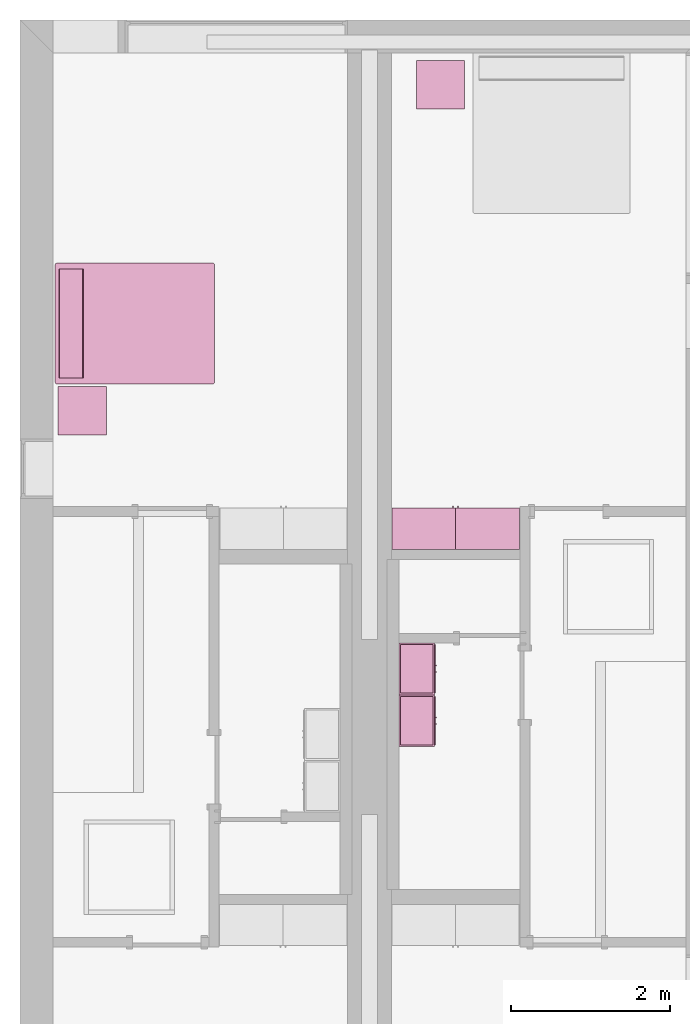
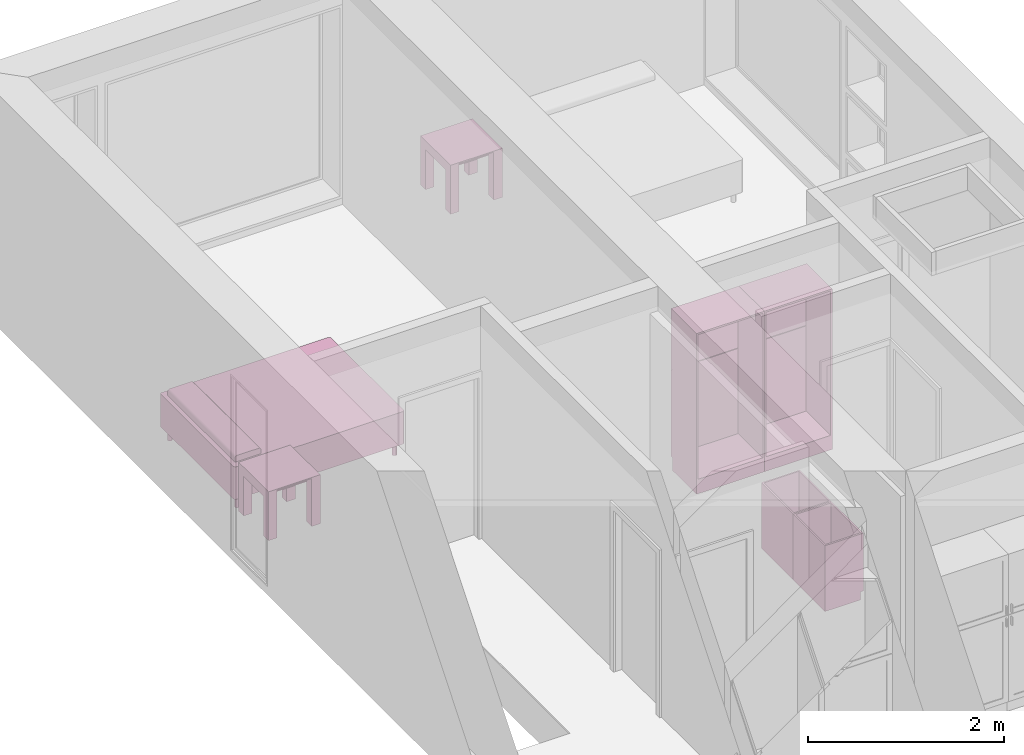
# One storey, part 9 of 10: 7 furnishings, 2 openings.
"""IFC2X3 building model written with IfcOpenShell, lengths in metres."""

from ifc_helpers import new_model, entity, si_unit, converted_unit, derived_unit, direction, frame, frame_2d, origin, origin_2d_with_axis, place, context, subcontext, project, spatial, polyline, circle_curve, parameter, trimmed, segment, composite_curve, rectangle, circle, outline, extrude, faceted_brep, source, transform, mapped, material, material_list, type_object, type_shapes, element, save


model = new_model("IFC2X3")

# Units and contexts
model_context = context("Model", 3, precision=1e-05, world=origin(), true_north=direction((6.12303176911189e-17, 1.0)))
body_context = subcontext(model_context, "Body", "Model", "MODEL_VIEW")
ifc_project = project(units=[derived_unit("USERDEFINED", [(si_unit("LENGTHUNIT", "METRE"), -2), (si_unit("TIMEUNIT", "SECOND"), -2), (si_unit("MASSUNIT", "GRAM", prefix="KILO"), 1)]), si_unit("FREQUENCYUNIT", "HERTZ"), si_unit("LENGTHUNIT", "METRE"), si_unit("ILLUMINANCEUNIT", "LUX"), derived_unit("LINEARVELOCITYUNIT", [(si_unit("TIMEUNIT", "SECOND"), -1), (si_unit("LENGTHUNIT", "METRE"), 1)]), si_unit("POWERUNIT", "WATT"), si_unit("LUMINOUSINTENSITYUNIT", "CANDELA"), si_unit("AREAUNIT", "SQUARE_METRE"), si_unit("VOLUMEUNIT", "CUBIC_METRE"), si_unit("ELECTRICVOLTAGEUNIT", "VOLT"), si_unit("PRESSUREUNIT", "PASCAL"), converted_unit("PLANEANGLEUNIT", "DEGREE", entity("IfcRatioMeasure", 0.0174532925199433), si_unit("PLANEANGLEUNIT", "RADIAN"), dimensions=[0, 0, 0, 0, 0, 0, 0]), si_unit("THERMODYNAMICTEMPERATUREUNIT", "DEGREE_CELSIUS"), si_unit("MASSUNIT", "GRAM", prefix="KILO"), derived_unit("VOLUMETRICFLOWRATEUNIT", [(si_unit("LENGTHUNIT", "METRE"), 3), (si_unit("TIMEUNIT", "SECOND"), -1)]), si_unit("TIMEUNIT", "SECOND"), si_unit("LUMINOUSFLUXUNIT", "LUMEN"), derived_unit("USERDEFINED", [(si_unit("LUMINOUSFLUXUNIT", "LUMEN"), 1), (si_unit("TIMEUNIT", "SECOND"), 3), (si_unit("MASSUNIT", "GRAM", prefix="KILO"), -1), (si_unit("LENGTHUNIT", "METRE"), -2)]), si_unit("FORCEUNIT", "NEWTON", prefix="KILO"), si_unit("ELECTRICCURRENTUNIT", "AMPERE"), derived_unit("THERMALTRANSMITTANCEUNIT", [(si_unit("TIMEUNIT", "SECOND"), -3), (si_unit("THERMODYNAMICTEMPERATUREUNIT", "KELVIN"), -1), (si_unit("MASSUNIT", "GRAM", prefix="KILO"), 1)])], contexts=[model_context])

# Site, building, storey, space
site_placement = place(None, origin())
site = spatial("IfcSite", under=ifc_project, at=site_placement, CompositionType="ELEMENT")
building_placement = place(site_placement, origin())
building = spatial("IfcBuilding", under=site, at=building_placement, CompositionType="ELEMENT")
storey_placement = place(building_placement, frame((0.0, 0.0, 3.10000000000038)))
storey = spatial("IfcBuildingStorey", under=building, at=storey_placement, Name="Level 2", CompositionType="ELEMENT", Elevation=3.10000000000038)
space_1_placement = place(storey_placement, origin())
space_1 = spatial("IfcSpace", under=storey, at=space_1_placement, CompositionType="ELEMENT", InteriorOrExteriorSpace="INTERNAL")

# Furnishing, opening
ifc_material_1 = material(Name="Cabinets")
ifc_material_2 = material(Name="Cabinets - Handles")
ifc_material_3 = material(Name="Cabinets - Panel")
ifc_material_list_1 = material_list([ifc_material_1, ifc_material_2, ifc_material_3])
ifc_material_list_2 = material_list([ifc_material_1, ifc_material_2, ifc_material_3])
furniture_type_1 = type_object("IfcFurnitureType", Name="800 mm", AssemblyPlace="NOTDEFINED", material=ifc_material_list_2)
shared_shape_1 = source(origin(), body_context, "Body", "SweptSolid", [
    extrude(outline(polyline([(-0.376138481652111, -0.4), (0.376138481652111, -0.4), (0.376138481652111, 0.4), (-0.376138481652111, 0.4), (-0.376138481652111, -0.4)]), holes=[polyline([(-0.312638481652032, -0.336499999999999), (-0.312638481652032, 0.336499999999999), (0.315813481652108, 0.336499999999999), (0.315813481652108, -0.336499999999999), (-0.312638481652032, -0.336499999999999)])]), frame((0.0187377049180258, -0.52, 1.62386151834792), z_axis=(0.0, 1.0, 0.0), x_axis=(0.0, 0.0, -1.0)), (0.0, 0.0, 1.0), 0.01905),
    extrude(outline(polyline([(-0.172299999999634, 0.558941666666897), (-0.172300000000835, -1.2794708333333), (0.328649999999164, -1.27947083333363), (0.32865000000047, 0.720529166666412), (-0.156349999999529, 0.720529166666729), (-0.156349999999635, 0.558941666666897), (-0.172299999999634, 0.558941666666897)])), frame((-0.381262295081959, -0.328649999999999, 0.720529166666627), z_axis=(-1.0, 0.0, 0.0), x_axis=(0.0, 1.0, 0.0)), (0.0, 0.0, -1.0), 0.8),
    extrude(rectangle(XDim=0.01905, YDim=0.761899999999999, at=origin_2d_with_axis()), frame((0.018737704918025, -0.009525, 0.180637499999846), z_axis=(0.0, 0.0, 1.0), x_axis=(0.0, 1.0, 0.0)), (0.0, 0.0, 1.0), 1.80031250000011),
    extrude(rectangle(XDim=0.00634999999999998, YDim=0.672999999999998, at=origin_2d_with_axis()), frame((0.0187377049180256, -0.504125, 0.225087499999839), z_axis=(0.0, 0.0, 1.0), x_axis=(0.0, 1.0, 0.0)), (0.0, 0.0, 1.0), 0.955960536695974),
    extrude(outline(polyline([(-0.4, -0.539892768347997), (0.4, -0.539892768347997), (0.4, 0.539892768347997), (-0.4, 0.539892768347997), (-0.4, -0.539892768347997)]), holes=[polyline([(-0.336499999999999, 0.479567768347999), (0.336499999999999, 0.479567768347999), (0.336499999999999, -0.476392768347979), (-0.336499999999999, -0.476392768347979), (-0.336499999999999, 0.479567768347999)])]), frame((0.0187377049180257, -0.52, 0.701480268347818), z_axis=(0.0, 1.0, 0.0), x_axis=(-1.0, 0.0, 0.0)), (0.0, 0.0, 1.0), 0.01905),
    extrude(rectangle(XDim=0.0254, YDim=0.0125322316306444, at=frame_2d((0.0, 3.38271077815477e-17), x_axis=(1.0, 0.0))), frame((0.387071589102703, -0.532700000000001, 1.26994803669581), z_axis=(0.0, 0.0, 1.0), x_axis=(0.0, 1.0, 0.0)), (0.0, 0.0, 1.0), 0.1016),
    extrude(rectangle(XDim=0.00634999999999998, YDim=0.672999999999998, at=origin_2d_with_axis()), frame((0.0187377049180261, -0.504125, 1.30804803669582), z_axis=(0.0, 0.0, 1.0), x_axis=(0.0, 1.0, 0.0)), (0.0, 0.0, 1.0), 0.62845196330414),
    extrude(rectangle(XDim=0.0254, YDim=0.0125322316306447, at=frame_2d((0.0, -3.38271077815477e-17), x_axis=(1.0, 0.0))), frame((0.387071589102702, -0.532700000000001, 1.11754803669582), z_axis=(0.0, 0.0, 1.0), x_axis=(0.0, 1.0, 0.0)), (0.0, 0.0, 1.0), 0.101599999999998),
])
type_shapes(furniture_type_1, [shared_shape_1])
furnishing_1_placement = place(space_1_placement, frame((5.90473770491803, -6.66600000000001, 0.0), z_axis=(0.0, 0.0, 1.0), x_axis=(-1.0, 0.0, 0.0)))
furnishing_1 = element("IfcFurnishingElement", 1, at=furnishing_1_placement, inside=space_1, type_object=furniture_type_1, material=ifc_material_list_1, ObjectType="800 mm", context=body_context, shape_type="MappedRepresentation", body=[
    mapped(shared_shape_1, transform((0.0, 0.0, 0.0), scale=1.0)),
])
opening_1_placement = place(storey_placement, frame((5.90473770491803, -6.66600000000001, 3.1000000000002)))
element("IfcOpeningElement", 2, at=opening_1_placement, cuts=furnishing_1, ObjectType="Opening", context=body_context, shape_type="SweptSolid", body=[
    extrude(rectangle(XDim=1.80031250000011, YDim=0.761899999999999, at=frame_2d((5.55111512312578e-17, 0.0), x_axis=(1.0, 0.0))), frame((-0.0187377049180267, 0.50095, -2.01920625000048), z_axis=(0.0, -1.0, 0.0), x_axis=(0.0, 0.0, -1.0)), (0.0, 0.0, 1.0), 0.50095),
])

ifc_material_list_3 = material_list([ifc_material_1, ifc_material_2, ifc_material_3])
ifc_material_list_4 = material_list([ifc_material_1, ifc_material_2, ifc_material_3])
furniture_type_2 = type_object("IfcFurnitureType", Name="800 mm", AssemblyPlace="NOTDEFINED", material=ifc_material_list_4)
shared_shape_2 = source(origin(), body_context, "Body", "SweptSolid", [
    extrude(rectangle(XDim=0.0125322316306444, YDim=0.0254, at=frame_2d((3.38271077815477e-17, 0.0), x_axis=(1.0, 0.0))), frame((0.387071589102703, 0.532700000000001, 1.26994803669581), z_axis=(0.0, 0.0, 1.0), x_axis=(-1.0, 0.0, 0.0)), (0.0, 0.0, 1.0), 0.1016),
    extrude(rectangle(XDim=0.761899999999999, YDim=0.01905, at=origin_2d_with_axis()), frame((0.018737704918025, 0.009525, 0.180637499999846), z_axis=(0.0, 0.0, 1.0), x_axis=(-1.0, 0.0, 0.0)), (0.0, 0.0, 1.0), 1.80031250000011),
    extrude(outline(polyline([(-0.558941666666786, -0.172299999999999), (1.27947083333342, -0.172299999999999), (1.27947083333342, 0.32865), (-0.720529166666629, 0.328649999999999), (-0.720529166666629, -0.15635), (-0.558941666666786, -0.15635), (-0.558941666666786, -0.172299999999999)])), frame((-0.38126229508196, 0.328649999999999, 0.720529166666629), z_axis=(1.0, 0.0, 0.0), x_axis=(0.0, 0.0, 1.0)), (0.0, 0.0, 1.0), 0.8),
    extrude(rectangle(XDim=0.672999999999998, YDim=0.00634999999999998, at=frame_2d((0.0, 6.76542155630955e-17), x_axis=(1.0, 0.0))), frame((0.0187377049180256, 0.504125, 0.225087499999839), z_axis=(0.0, 0.0, 1.0), x_axis=(-1.0, 0.0, 0.0)), (0.0, 0.0, 1.0), 0.955960536695974),
    extrude(rectangle(XDim=0.672999999999998, YDim=0.00634999999999998, at=frame_2d((0.0, 6.76542155630955e-17), x_axis=(1.0, 0.0))), frame((0.0187377049180261, 0.504125, 1.30804803669582), z_axis=(0.0, 0.0, 1.0), x_axis=(-1.0, 0.0, 0.0)), (0.0, 0.0, 1.0), 0.62845196330414),
    extrude(outline(polyline([(-0.376138481652111, -0.4), (0.376138481652111, -0.4), (0.376138481652111, 0.4), (-0.376138481652111, 0.4), (-0.376138481652111, -0.4)]), holes=[polyline([(-0.312638481652032, -0.3365), (-0.312638481652032, 0.336499999999999), (0.315813481652108, 0.336499999999999), (0.315813481652108, -0.3365), (-0.312638481652032, -0.3365)])]), frame((0.0187377049180258, 0.50095, 1.62386151834792), z_axis=(0.0, 1.0, 0.0), x_axis=(0.0, 0.0, -1.0)), (0.0, 0.0, 1.0), 0.01905),
    extrude(rectangle(XDim=0.0125322316306447, YDim=0.0254, at=frame_2d((-3.38271077815477e-17, 0.0), x_axis=(1.0, 0.0))), frame((0.387071589102702, 0.532700000000001, 1.11754803669582), z_axis=(0.0, 0.0, 1.0), x_axis=(-1.0, 0.0, 0.0)), (0.0, 0.0, 1.0), 0.101599999999998),
    extrude(outline(polyline([(-0.4, -0.539892768347997), (0.4, -0.539892768347997), (0.4, 0.539892768347997), (-0.4, 0.539892768347997), (-0.4, -0.539892768347997)]), holes=[polyline([(-0.336499999999999, 0.479567768347999), (0.336499999999999, 0.479567768347999), (0.336499999999999, -0.476392768347979), (-0.336499999999999, -0.476392768347979), (-0.336499999999999, 0.479567768347999)])]), frame((0.0187377049180257, 0.50095, 0.701480268347818), z_axis=(0.0, 1.0, 0.0), x_axis=(-1.0, 0.0, 0.0)), (0.0, 0.0, 1.0), 0.01905),
])
type_shapes(furniture_type_2, [shared_shape_2])
furnishing_2_placement = place(space_1_placement, frame((5.06726229508198, -6.666, 0.0)))
furnishing_2 = element("IfcFurnishingElement", 3, at=furnishing_2_placement, inside=space_1, type_object=furniture_type_2, material=ifc_material_list_3, ObjectType="800 mm", context=body_context, shape_type="MappedRepresentation", body=[
    mapped(shared_shape_2, transform((0.0, 0.0, 0.0), scale=1.0)),
])
opening_2_placement = place(storey_placement, frame((5.06726229508198, -6.666, 3.1000000000002)))
element("IfcOpeningElement", 4, at=opening_2_placement, cuts=furnishing_2, ObjectType="Opening", context=body_context, shape_type="SweptSolid", body=[
    extrude(rectangle(XDim=1.80031250000011, YDim=0.761899999999999, at=frame_2d((5.55111512312578e-17, 0.0), x_axis=(1.0, 0.0))), frame((0.0187377049180251, 0.0, -2.01920625000048), z_axis=(0.0, 1.0, 0.0), x_axis=(0.0, 0.0, -1.0)), (0.0, 0.0, 1.0), 0.50095),
])

# Space
space_2_placement = place(storey_placement, origin())
space_2 = spatial("IfcSpace", under=storey, at=space_2_placement, CompositionType="ELEMENT", InteriorOrExteriorSpace="INTERNAL")

# Furnishings
ifc_material_4 = material(Name="Wood - Teak")
ifc_material_5 = material(Name="Glass - Clear, Grey")
ifc_material_6 = material(Name="Metal - Chrome")
ifc_material_list_5 = material_list([ifc_material_4, ifc_material_5, ifc_material_6])
ifc_material_list_6 = material_list([ifc_material_4, ifc_material_5, ifc_material_6])
furniture_type_3 = type_object("IfcFurnitureType", Name="0610 x 0610 x 0610mm", AssemblyPlace="NOTDEFINED", material=ifc_material_list_6)
shared_shape_3 = source(origin(), body_context, "Body", "SweptSolid", [
    extrude(rectangle(XDim=0.406799999999999, YDim=0.4068, at=origin_2d_with_axis()), frame((0.0182657666726316, 0.0952110778022263, 0.4957), z_axis=(0.0, 0.0, 1.0), x_axis=(-1.0, 0.0, 0.0)), (0.0, 0.0, 1.0), 0.0127),
    extrude(outline(polyline([(-0.273249999999994, -0.305), (0.324049999999978, -0.305), (0.324049999999978, 0.304999999999998), (-0.273249999999993, 0.304999999999999), (-0.273249999999993, 0.203400000000001), (0.222450000000009, 0.203400000000001), (0.222450000000009, -0.2034), (-0.273249999999994, -0.2034), (-0.273249999999994, -0.305)])), frame((0.221665766672633, 0.0952110778022354, 0.273249999999992), z_axis=(1.0, 0.0, 0.0), x_axis=(0.0, 0.0, 1.0)), (0.0, 0.0, 1.0), 0.1016),
    extrude(outline(polyline([(-0.305, -0.305000000000023), (0.305, -0.305000000000023), (0.305, 0.305000000000023), (-0.305, 0.305000000000023), (-0.305, -0.305000000000023)]), holes=[polyline([(-0.203399999999998, -0.203399999999975), (-0.203399999999998, 0.203400000000025), (0.203400000000001, 0.203400000000025), (0.203400000000001, -0.203399999999975), (-0.203399999999998, -0.203399999999975)])]), frame((0.0182657666726332, 0.0952110778022508, 0.5973), z_axis=(0.0, 0.0, 1.0), x_axis=(-1.0, 0.0, 0.0)), (0.0, 0.0, 1.0), 0.0127),
    extrude(outline(polyline([(-0.305000000000004, -0.324050000000026), (0.304999999999994, -0.324050000000026), (0.304999999999994, 0.273250000000011), (0.203400000000004, 0.273250000000011), (0.203400000000004, -0.222449999999996), (-0.203399999999994, -0.222449999999996), (-0.203399999999994, 0.273250000000011), (-0.305000000000004, 0.273250000000011), (-0.305000000000004, -0.324050000000026)])), frame((-0.286734233327367, 0.0952110778022256, 0.273250000000008), z_axis=(1.0, 0.0, 0.0), x_axis=(0.0, -1.0, 0.0)), (0.0, 0.0, 1.0), 0.1016),
    extrude(rectangle(XDim=0.406799999999999, YDim=0.4068, at=origin_2d_with_axis()), frame((0.0182657666726316, 0.0952110778022259, 0.5973), z_axis=(0.0, 0.0, 1.0), x_axis=(-1.0, 0.0, 0.0)), (0.0, 0.0, 1.0), 0.0127),
])
type_shapes(furniture_type_3, [shared_shape_3])
furnishing_3_placement = place(space_2_placement, frame((0.763734233327367, -5.01221107780223, 0.0189999999998181)))
element("IfcFurnishingElement", 5, at=furnishing_3_placement, inside=space_2, type_object=furniture_type_3, material=ifc_material_list_5, Name="M_Table-Coffee:0610 x 0610 x 0610mm", ObjectType="0610 x 0610 x 0610mm", context=body_context, shape_type="MappedRepresentation", body=[
    mapped(shared_shape_3, transform((0.0, 0.0, 0.0), scale=1.0)),
])
ifc_material_list_7 = material_list([ifc_material_4, ifc_material_5, ifc_material_6])
furnishing_4_placement = place(space_1_placement, frame((5.27573423332738, -0.91221107780225, 0.0189999999998181)))
element("IfcFurnishingElement", 6, at=furnishing_4_placement, inside=space_1, type_object=furniture_type_3, material=ifc_material_list_7, Name="M_Table-Coffee:0610 x 0610 x 0610mm", ObjectType="0610 x 0610 x 0610mm", context=body_context, shape_type="MappedRepresentation", body=[
    mapped(shared_shape_3, transform((0.0, 0.0, 0.0), scale=1.0)),
])
ifc_material_7 = material(Name="Textile - White")
ifc_material_list_8 = material_list([ifc_material_7, ifc_material_6])
ifc_material_list_9 = material_list([ifc_material_7, ifc_material_6])
furniture_type_4 = type_object("IfcFurnitureType", Name="1525 x 2007mm - Queen", AssemblyPlace="NOTDEFINED", material=ifc_material_list_9)
shared_shape_4 = source(origin(), body_context, "Body", "SweptSolid", [
    extrude(outline(composite_curve([segment(polyline([(-0.1524, -0.0423333333333332), (0.1524, -0.0423333333333332)]), True, "CONTINUOUS"), segment(polyline([(0.1524, -0.0423333333333332), (0.1524, 0.00846666666666662)]), True, "CONTINUOUS"), segment(trimmed(circle_curve(frame_2d((0.127, 0.00846666666666662), x_axis=(-1.0, 0.0)), 0.0254), [parameter(180.0)], [parameter(270.0)], True, "PARAMETER"), True, "CONTINUOUS"), segment(polyline([(0.127, 0.0338666666666666), (-0.127, 0.0338666666666666)]), True, "CONTINUOUS"), segment(trimmed(circle_curve(frame_2d((-0.127, 0.00846666666666673), x_axis=(-1.0, 0.0)), 0.0254), [parameter(270.0)], [parameter(0.0)], True, "PARAMETER"), True, "CONTINUOUS"), segment(polyline([(-0.1524, 0.00846666666666673), (-0.1524, -0.0423333333333332)]), True, "CONTINUOUS")], self_intersect=False)), frame((-0.414811475409804, 0.754704918032813, 0.601133333333333), z_axis=(1.0, 0.0, 0.0), x_axis=(0.0, 1.0, 0.0)), (0.0, 0.0, 1.0), 1.37259999999997),
    extrude(circle(Radius=0.0253999999999999, at=origin_2d_with_axis()), frame((-0.414811475409829, 0.881704918032795, 0.0)), (0.0, 0.0, 1.0), 0.1524),
    extrude(circle(Radius=0.0254000000000034, at=frame_2d((-6.76791955811495e-17, -1.35358391162299e-16), x_axis=(1.0, 0.0))), frame((-0.414811475409807, -0.972895081967205, 0.0)), (0.0, 0.0, 1.0), 0.1524),
    extrude(circle(Radius=0.0254000000000244, at=origin_2d_with_axis()), frame((0.957788524590165, 0.881704918032822, 0.0)), (0.0, 0.0, 1.0), 0.1524),
    extrude(outline(composite_curve([segment(trimmed(circle_curve(frame_2d((-0.737099999999989, -0.978100000000009), x_axis=(1.0, 0.0)), 0.0254000000000003), [parameter(180.0)], [parameter(270.0)], True, "PARAMETER"), True, "CONTINUOUS"), segment(polyline([(-0.737099999999989, -1.00350000000001), (0.737100000000009, -1.00350000000001)]), True, "CONTINUOUS"), segment(trimmed(circle_curve(frame_2d((0.737100000000009, -0.978100000000034), x_axis=(1.0, 0.0)), 0.0253999999999749), [parameter(270.0)], [parameter(360.0)], True, "PARAMETER"), True, "CONTINUOUS"), segment(polyline([(0.762499999999984, -0.978100000000034), (0.762499999999984, 0.97810000000004)]), True, "CONTINUOUS"), segment(trimmed(circle_curve(frame_2d((0.737100000000033, 0.97810000000004), x_axis=(1.0, 0.0)), 0.0253999999999504), [parameter(0.0)], [parameter(90.0000000000001)], True, "PARAMETER"), True, "CONTINUOUS"), segment(polyline([(0.737100000000033, 1.00349999999999), (-0.737100000000041, 1.00349999999999)]), True, "CONTINUOUS"), segment(trimmed(circle_curve(frame_2d((-0.737100000000041, 0.978100000000042), x_axis=(1.0, 0.0)), 0.0253999999999488), [parameter(90.0000000000001)], [parameter(180.0)], True, "PARAMETER"), True, "CONTINUOUS"), segment(polyline([(-0.76249999999999, 0.978100000000042), (-0.76249999999999, -0.978100000000009)]), True, "CONTINUOUS")], self_intersect=False)), frame((0.271488524590183, -0.0455950819671924, 0.1524)), (0.0, 0.0, 1.0), 0.2032),
    extrude(circle(Radius=0.0254, at=frame_2d((0.0, -1.35358391162299e-16), x_axis=(1.0, 0.0))), frame((0.957788524590184, -0.972895081967175, 0.0)), (0.0, 0.0, 1.0), 0.1524),
    extrude(outline(composite_curve([segment(trimmed(circle_curve(frame_2d((-0.73710000000004, 0.978100000000041), x_axis=(1.0, 0.0)), 0.0253999999999498), [parameter(90.0000000000001)], [parameter(180.0)], True, "PARAMETER"), True, "CONTINUOUS"), segment(polyline([(-0.76249999999999, 0.978100000000041), (-0.76249999999999, -0.978100000000009)]), True, "CONTINUOUS"), segment(trimmed(circle_curve(frame_2d((-0.737099999999989, -0.978100000000009), x_axis=(1.0, 0.0)), 0.0254000000000007), [parameter(180.0)], [parameter(270.0)], True, "PARAMETER"), True, "CONTINUOUS"), segment(polyline([(-0.737099999999989, -1.00350000000001), (0.737100000000009, -1.00350000000001)]), True, "CONTINUOUS"), segment(trimmed(circle_curve(frame_2d((0.737100000000009, -0.978100000000035), x_axis=(1.0, 0.0)), 0.0253999999999751), [parameter(270.0)], [parameter(359.999999999999)], True, "PARAMETER"), True, "CONTINUOUS"), segment(polyline([(0.762499999999984, -0.978100000000035), (0.762499999999984, 0.978100000000041)]), True, "CONTINUOUS"), segment(trimmed(circle_curve(frame_2d((0.737100000000034, 0.978100000000041), x_axis=(1.0, 0.0)), 0.0253999999999497), [parameter(360.0)], [parameter(89.9999999999998)], True, "PARAMETER"), True, "CONTINUOUS"), segment(polyline([(0.737100000000034, 1.00349999999999), (-0.737100000000041, 1.00349999999999)]), True, "CONTINUOUS")], self_intersect=False)), frame((0.271488524590183, -0.045595081967192, 0.3556)), (0.0, 0.0, 1.0), 0.2032),
])
type_shapes(furniture_type_4, [shared_shape_4])
furnishing_5_placement = place(space_2_placement, frame((1.4009049180328, -4.09348852459019, 0.0), z_axis=(0.0, 0.0, 1.0), x_axis=(0.0, 1.0, 0.0)))
element("IfcFurnishingElement", 7, at=furnishing_5_placement, inside=space_2, type_object=furniture_type_4, material=ifc_material_list_8, Name="M_Bed-Standard:1525 x 2007mm - Queen", ObjectType="1525 x 2007mm - Queen", context=body_context, shape_type="MappedRepresentation", body=[
    mapped(shared_shape_4, transform((0.0, 0.0, 0.0), scale=1.0)),
])

# Space
space_3_placement = place(storey_placement, origin())
space_3 = spatial("IfcSpace", under=storey, at=space_3_placement, CompositionType="ELEMENT", InteriorOrExteriorSpace="INTERNAL")

# Furnishings
ifc_material_list_10 = material_list([ifc_material_1, ifc_material_2])
ifc_material_list_11 = material_list([ifc_material_1, ifc_material_2])
furniture_type_5 = type_object("IfcFurnitureType", Name="650 x 450 mm", AssemblyPlace="NOTDEFINED", material=ifc_material_list_11)
shared_shape_5 = source(origin(), body_context, "Body", "Brep", [
    faceted_brep([(-0.287212295081975, 0.430950000000001, 0.119049999999842), (-0.287212295081975, 0.430950000000001, 0.0999999999999994), (-0.287212295081975, 0.0190499999999988, 0.0999999999999994), (-0.287212295081975, 0.0190499999999988, 0.119049999999842), (0.324687704918028, 0.0190499999999988, 0.119049999999842), (0.324687704918028, 0.0190499999999988, 0.0999999999999994), (0.324687704918028, 0.430950000000001, 0.0999999999999994), (0.324687704918028, 0.430950000000001, 0.119049999999842)], [[[0, 1, 2, 3]], [[4, 5, 6, 7]], [[3, 2, 5, 4]], [[4, 7, 0, 3]], [[7, 6, 1, 0]], [[5, 2, 1, 6]]]),
    faceted_brep([(-0.287212295081494, 0.462699999999999, 0.680300000000006), (-0.287212295081494, 0.449999999999999, 0.680300000000006), (0.0092127049179239, 0.45, 0.680300000000006), (0.00921270491792386, 0.4627, 0.680300000000006), (0.00921270491792386, 0.4627, 0.119049999999842), (-0.287212295081494, 0.462699999999999, 0.119049999999842), (0.0092127049179239, 0.45, 0.119049999999842), (-0.287212295081494, 0.449999999999999, 0.119049999999842)], [[[0, 1, 2, 3]], [[3, 4, 5, 0]], [[4, 6, 7, 5]], [[2, 1, 7, 6]], [[5, 7, 1, 0]], [[3, 2, 6, 4]]]),
    faceted_brep([(-0.306262295081973, 0.0, 0.82), (0.343737704918026, 0.0, 0.82), (0.324687704918028, 0.0190499999999988, 0.82), (-0.287212295081975, 0.0190499999999988, 0.82), (-0.287212295081975, 0.430950000000001, 0.0999999999999995), (-0.287212295081975, 0.414999999999998, 0.0999999999999994), (-0.306262295081973, 0.414999999999998, 0.0999999999999995), (-0.306262295081973, 0.45, 0.0999999999999995), (0.343737704918026, 0.45, 0.82), (0.343737704918026, 0.45, 0.0999999999999995), (-0.306262295081973, 0.45, 0.82), (0.343737704918026, 0.0, 0.0), (-0.306262295081973, 0.0, 0.0), (-0.306262295081973, 0.414999999999998, 0.0), (0.343737704918026, 0.414999999999998, 0.0), (0.324687704918028, 0.430950000000001, 0.82), (-0.287212295081975, 0.430950000000001, 0.82), (0.324687704918028, 0.430950000000001, 0.0999999999999995), (0.324687704918028, 0.0190499999999988, 0.0999999999999995), (-0.287212295081975, 0.0190499999999988, 0.0999999999999995), (0.343737704918026, 0.414999999999998, 0.0999999999999995), (0.324687704918028, 0.414999999999998, 0.0999999999999995)], [[[0, 1, 2, 3]], [[4, 5, 6, 7]], [[8, 9, 7, 10]], [[11, 12, 13, 14]], [[12, 11, 1, 0]], [[15, 8, 10, 16]], [[4, 7, 9, 17]], [[7, 6, 13, 12, 0, 10]], [[3, 2, 18, 19]], [[9, 20, 21, 17]], [[15, 16, 4, 17]], [[17, 21, 18, 2, 15]], [[8, 1, 11, 14, 20, 9]], [[16, 3, 19, 5, 4]], [[13, 6, 5, 21, 20, 14]], [[10, 0, 3, 16]], [[15, 2, 1, 8]], [[5, 19, 18, 21]]]),
    faceted_brep([(0.324687704918537, 0.450000000000001, 0.800950000000086), (-0.287212295081482, 0.449999999999999, 0.800950000000086), (-0.287212295081482, 0.449999999999999, 0.699350000000061), (0.324687704918537, 0.450000000000001, 0.699350000000061), (0.324687704918537, 0.462700000000001, 0.800950000000086), (0.324687704918537, 0.462700000000001, 0.699350000000061), (-0.287212295081482, 0.462699999999999, 0.800950000000086), (-0.287212295081482, 0.462699999999999, 0.699350000000061)], [[[0, 1, 2, 3]], [[4, 0, 3, 5]], [[6, 1, 0, 4]], [[7, 2, 1, 6]], [[4, 5, 7, 6]], [[5, 3, 2, 7]]]),
    faceted_brep([(-0.016187295081974, 0.4754, 0.517469895035161), (-0.016187295081974, 0.4627, 0.517469895035161), (-0.0288872950819743, 0.4627, 0.517469895035161), (-0.0288872950819744, 0.4754, 0.517469895035161), (-0.016187295081974, 0.4754, 0.642200000000001), (-0.016187295081974, 0.4627, 0.642200000000001), (-0.0288872950819744, 0.4754, 0.642200000000001), (-0.0288872950819743, 0.4627, 0.642200000000001)], [[[0, 1, 2, 3]], [[4, 5, 1, 0]], [[6, 7, 5, 4]], [[4, 0, 3, 6]], [[3, 2, 7, 6]], [[5, 7, 2, 1]]]),
    faceted_brep([(0.0663627049179473, 0.4754, 0.642200000000001), (0.0663627049179473, 0.4754, 0.517469895035163), (0.0536627049179471, 0.4754, 0.517469895035163), (0.0536627049179471, 0.4754, 0.642200000000001), (0.0536627049179471, 0.4627, 0.642200000000001), (0.0663627049179473, 0.4627, 0.642200000000001), (0.0536627049179471, 0.4627, 0.517469895035163), (0.0663627049179473, 0.4627, 0.517469895035163)], [[[0, 1, 2, 3]], [[3, 4, 5, 0]], [[5, 4, 6, 7]], [[1, 7, 6, 2]], [[0, 5, 7, 1]], [[2, 6, 4, 3]]]),
    faceted_brep([(0.324687704918534, 0.462700000000001, 0.680300000000043), (0.324687704918534, 0.462700000000001, 0.119049999999857), (0.0282627049178735, 0.4627, 0.119049999999857), (0.0282627049178735, 0.4627, 0.680300000000043), (0.324687704918534, 0.450000000000001, 0.680300000000043), (0.324687704918534, 0.450000000000001, 0.119049999999857), (0.0282627049178735, 0.45, 0.680300000000043), (0.0282627049178735, 0.45, 0.119049999999857)], [[[0, 1, 2, 3]], [[0, 4, 5, 1]], [[3, 6, 4, 0]], [[2, 7, 6, 3]], [[1, 5, 7, 2]], [[4, 6, 7, 5]]]),
])
type_shapes(furniture_type_5, [shared_shape_5])
furnishing_6_placement = place(space_3_placement, frame((4.77000000000002, -8.8016465301535, 0.0129999999998178), z_axis=(0.0, 0.0, 1.0), x_axis=(0.0, -1.0, 0.0)))
element("IfcFurnishingElement", 8, at=furnishing_6_placement, inside=space_3, type_object=furniture_type_5, material=ifc_material_list_10, Name="M_Vanity Cabinet-Double Door Sink Unit:650 x 450 mm", ObjectType="650 x 450 mm", context=body_context, shape_type="MappedRepresentation", body=[
    mapped(shared_shape_5, transform((0.0, 0.0, 0.0), scale=1.0)),
])
ifc_material_list_12 = material_list([ifc_material_1, ifc_material_2])
furnishing_7_placement = place(space_3_placement, frame((4.77000000000002, -8.1516465301535, 0.0129999999998178), z_axis=(0.0, 0.0, 1.0), x_axis=(0.0, -1.0, 0.0)))
element("IfcFurnishingElement", 9, at=furnishing_7_placement, inside=space_3, type_object=furniture_type_5, material=ifc_material_list_12, Name="M_Vanity Cabinet-Double Door Sink Unit:650 x 450 mm", ObjectType="650 x 450 mm", context=body_context, shape_type="MappedRepresentation", body=[
    mapped(shared_shape_5, transform((0.0, 0.0, 0.0), scale=1.0)),
])

save(model, "model.ifc")
